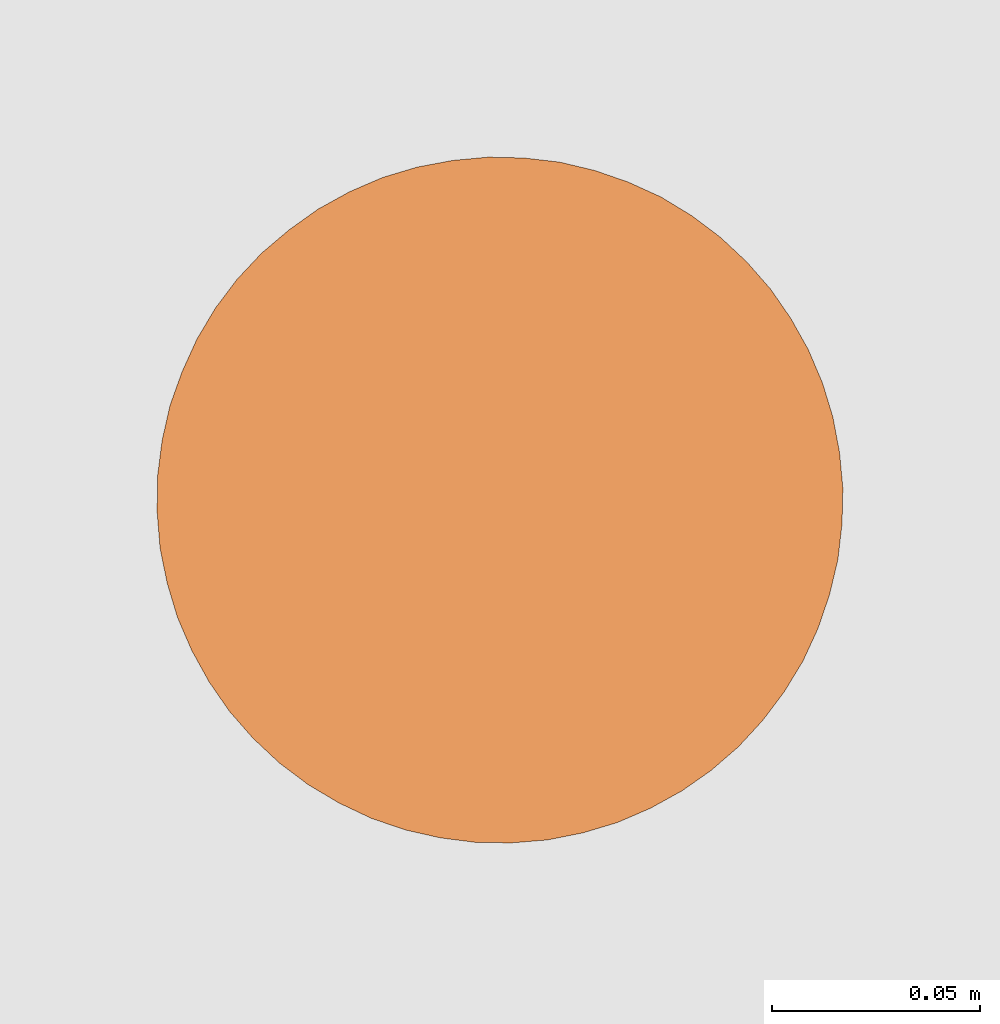
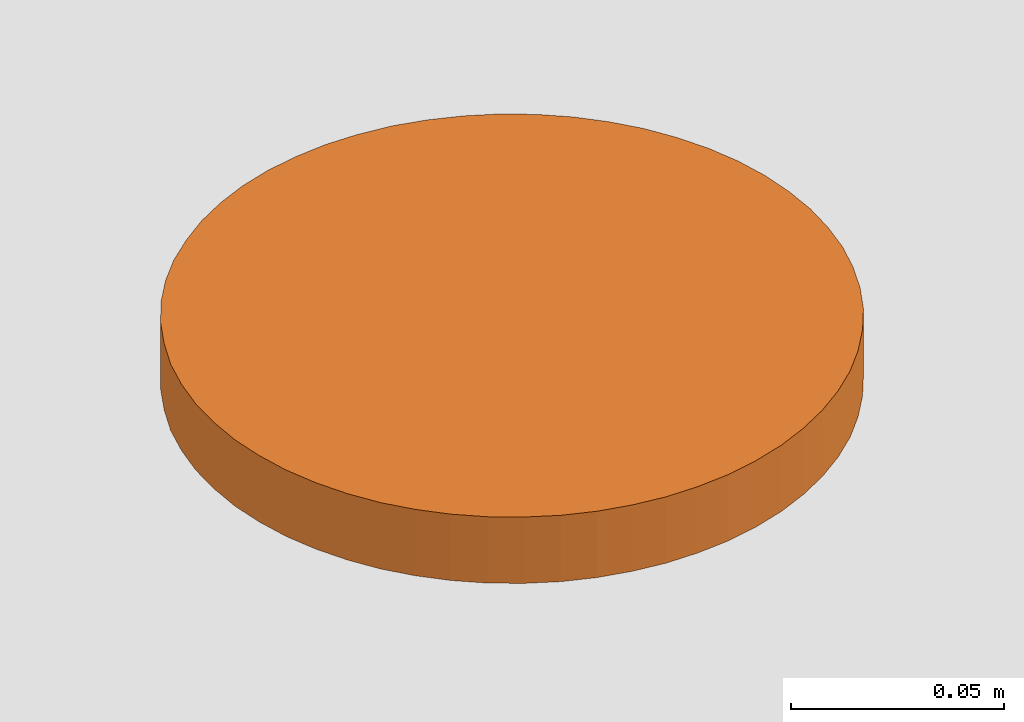
# One storey, part 86 of 126: 1 proxy.
"""IFC2X3 building model written with IfcOpenShell, lengths in millimetres."""

from ifc_helpers import new_model, si_unit, origin, origin_with_axes, place, context, project, spatial, faceted_brep, material, element, save


model = new_model("IFC2X3")

# Units and contexts
context_of_model_1 = context(None, 3, precision=0.1, world=origin())
context_of_model_2 = context(None, 3, precision=0.1, world=origin())
ifc_project = project(units=[si_unit("LENGTHUNIT", "METRE", prefix="MILLI"), si_unit("AREAUNIT", "SQUARE_METRE", prefix="CENTI"), si_unit("VOLUMEUNIT", "CUBIC_METRE", prefix="CENTI"), si_unit("MASSUNIT", "GRAM", prefix="KILO")], contexts=[context_of_model_1, context_of_model_2])

# Site, building, storey
site_placement = place(None, origin_with_axes())
site = spatial("IfcSite", under=ifc_project, at=site_placement, CompositionType="ELEMENT")
building_placement = place(site_placement, origin_with_axes())
building = spatial("IfcBuilding", under=site, at=building_placement, CompositionType="ELEMENT")
storey_placement = place(building_placement, origin_with_axes())
storey = spatial("IfcBuildingStorey", under=building, at=storey_placement, CompositionType="ELEMENT")

# Proxy
ifc_material = material(Name="STAHL")
proxy_placement = place(storey_placement, origin_with_axes())
element("IfcBuildingElementProxy", 1, at=proxy_placement, inside=storey, material=ifc_material, Name="profile", context=context_of_model_2, shape_type="Brep", body=[
    faceted_brep([(6813.8, 14727.6, 10998.9), (6822.3, 14729.2, 10998.9), (6822.3, 14729.2, 10979.9), (6813.8, 14727.6, 10979.9), (6805.5, 14725.1, 10998.9), (6805.5, 14725.1, 10979.9), (6797.6, 14721.7, 10998.9), (6797.6, 14721.7, 10979.9), (6916.0, 14641.8, 10998.9), (6915.0, 14633.2, 10998.9), (6915.0, 14633.2, 10979.9), (6916.0, 14641.8, 10979.9), (6790.0, 14717.5, 10998.9), (6790.0, 14717.5, 10979.9), (6916.2, 14650.4, 10998.9), (6916.2, 14650.4, 10979.9), (6783.0, 14712.5, 10998.9), (6783.0, 14712.5, 10979.9), (6915.4, 14659.0, 10998.9), (6915.4, 14659.0, 10979.9), (6776.4, 14706.9, 10998.9), (6776.4, 14706.9, 10979.9), (6913.8, 14667.5, 10998.9), (6913.8, 14667.5, 10979.9), (6770.5, 14700.6, 10998.9), (6770.5, 14700.6, 10979.9), (6911.3, 14675.7, 10998.9), (6911.3, 14675.7, 10979.9), (6765.3, 14693.7, 10998.9), (6765.3, 14693.7, 10979.9), (6907.9, 14683.7, 10998.9), (6907.9, 14683.7, 10979.9), (6760.9, 14686.3, 10998.9), (6760.9, 14686.3, 10979.9), (6903.7, 14691.2, 10998.9), (6903.7, 14691.2, 10979.9), (6757.3, 14678.4, 10998.9), (6757.3, 14678.4, 10979.9), (6898.8, 14698.3, 10998.9), (6898.8, 14698.3, 10979.9), (6754.4, 14670.3, 10998.9), (6754.4, 14670.3, 10979.9), (6893.1, 14704.8, 10998.9), (6893.1, 14704.8, 10979.9), (6752.5, 14661.9, 10998.9), (6752.5, 14661.9, 10979.9), (6886.8, 14710.7, 10998.9), (6886.8, 14710.7, 10979.9), (6879.9, 14715.9, 10998.9), (6879.9, 14715.9, 10979.9), (6872.5, 14720.4, 10998.9), (6872.5, 14720.4, 10979.9), (6864.6, 14724.0, 10998.9), (6864.6, 14724.0, 10979.9), (6856.5, 14726.8, 10998.9), (6856.5, 14726.8, 10979.9), (6848.1, 14728.8, 10998.9), (6848.1, 14728.8, 10979.9), (6839.5, 14729.8, 10998.9), (6839.5, 14729.8, 10979.9), (6830.9, 14730.0, 10998.9), (6830.9, 14730.0, 10979.9), (6864.5, 14647.5, 10998.9), (6864.5, 14647.5, 10979.9), (6864.0, 14642.2, 10979.9), (6864.0, 14642.2, 10998.9), (6864.0, 14652.9, 10998.9), (6864.0, 14652.9, 10979.9), (6862.6, 14658.0, 10998.9), (6862.6, 14658.0, 10979.9), (6860.4, 14662.9, 10998.9), (6860.4, 14662.9, 10979.9), (6857.3, 14667.3, 10998.9), (6857.3, 14667.3, 10979.9), (6853.5, 14671.1, 10998.9), (6853.5, 14671.1, 10979.9), (6849.1, 14674.2, 10998.9), (6849.1, 14674.2, 10979.9), (6844.3, 14676.4, 10998.9), (6844.3, 14676.4, 10979.9), (6839.1, 14677.8, 10998.9), (6839.1, 14677.8, 10979.9), (6833.7, 14678.3, 10998.9), (6833.7, 14678.3, 10979.9), (6828.4, 14677.8, 10998.9), (6828.4, 14677.8, 10979.9), (6823.2, 14676.4, 10998.9), (6823.2, 14676.4, 10979.9), (6818.4, 14674.2, 10998.9), (6818.4, 14674.2, 10979.9), (6814.0, 14671.1, 10998.9), (6814.0, 14671.1, 10979.9), (6810.2, 14667.3, 10998.9), (6810.2, 14667.3, 10979.9), (6807.1, 14662.9, 10998.9), (6807.1, 14662.9, 10979.9), (6804.8, 14658.0, 10998.9), (6804.8, 14658.0, 10979.9), (6803.5, 14652.9, 10998.9), (6803.5, 14652.9, 10979.9), (6878.5, 14594.8, 10998.9), (6878.6, 14596.9, 10998.9), (6878.6, 14596.9, 10979.9), (6878.5, 14594.8, 10979.9), (6878.2, 14599.1, 10998.9), (6878.2, 14599.1, 10979.9), (6877.3, 14601.0, 10998.9), (6877.3, 14601.0, 10979.9), (6875.9, 14602.7, 10998.9), (6875.9, 14602.7, 10979.9), (6874.2, 14604.1, 10998.9), (6874.2, 14604.1, 10979.9), (6872.2, 14604.9, 10998.9), (6872.2, 14604.9, 10979.9), (6870.1, 14605.3, 10998.9), (6870.1, 14605.3, 10979.9), (6867.9, 14605.2, 10998.9), (6867.9, 14605.2, 10979.9), (6865.8, 14604.5, 10998.9), (6865.8, 14604.5, 10979.9), (6864.0, 14603.4, 10998.9), (6864.0, 14603.4, 10979.9), (6862.5, 14601.8, 10998.9), (6862.5, 14601.8, 10979.9), (6861.4, 14600.0, 10998.9), (6861.4, 14600.0, 10979.9), (6860.7, 14597.9, 10998.9), (6860.7, 14597.9, 10979.9), (6806.8, 14697.2, 10998.9), (6806.9, 14699.3, 10998.9), (6806.9, 14699.3, 10979.9), (6806.8, 14697.2, 10979.9), (6806.5, 14701.5, 10998.9), (6806.5, 14701.5, 10979.9), (6805.6, 14703.4, 10998.9), (6805.6, 14703.4, 10979.9), (6804.2, 14705.1, 10998.9), (6804.2, 14705.1, 10979.9), (6802.5, 14706.5, 10998.9), (6802.5, 14706.5, 10979.9), (6800.5, 14707.3, 10998.9), (6800.5, 14707.3, 10979.9), (6798.4, 14707.7, 10998.9), (6798.4, 14707.7, 10979.9), (6796.2, 14707.6, 10998.9), (6796.2, 14707.6, 10979.9), (6794.1, 14706.9, 10998.9), (6794.1, 14706.9, 10979.9), (6792.3, 14705.8, 10998.9), (6792.3, 14705.8, 10979.9), (6790.8, 14704.2, 10998.9), (6790.8, 14704.2, 10979.9), (6789.7, 14702.4, 10998.9), (6789.7, 14702.4, 10979.9), (6789.0, 14700.3, 10998.9), (6789.0, 14700.3, 10979.9), (6893.8, 14681.8, 10998.9), (6893.9, 14684.0, 10998.9), (6893.9, 14684.0, 10979.9), (6893.8, 14681.8, 10979.9), (6893.5, 14686.1, 10998.9), (6893.5, 14686.1, 10979.9), (6892.6, 14688.1, 10998.9), (6892.6, 14688.1, 10979.9), (6891.3, 14689.8, 10998.9), (6891.3, 14689.8, 10979.9), (6889.5, 14691.1, 10998.9), (6889.5, 14691.1, 10979.9), (6887.6, 14692.0, 10998.9), (6887.6, 14692.0, 10979.9), (6885.4, 14692.4, 10998.9), (6885.4, 14692.4, 10979.9), (6883.3, 14692.2, 10998.9), (6883.3, 14692.2, 10979.9), (6881.2, 14691.6, 10998.9), (6881.2, 14691.6, 10979.9), (6879.3, 14690.4, 10998.9), (6879.3, 14690.4, 10979.9), (6877.8, 14688.9, 10998.9), (6877.8, 14688.9, 10979.9), (6876.7, 14687.0, 10998.9), (6876.7, 14687.0, 10979.9), (6876.1, 14684.9, 10998.9), (6876.1, 14684.9, 10979.9), (6791.4, 14610.1, 10998.9), (6791.5, 14612.3, 10998.9), (6791.5, 14612.3, 10979.9), (6791.4, 14610.1, 10979.9), (6791.1, 14614.4, 10998.9), (6791.1, 14614.4, 10979.9), (6790.2, 14616.4, 10998.9), (6790.2, 14616.4, 10979.9), (6788.9, 14618.1, 10998.9), (6788.9, 14618.1, 10979.9), (6787.2, 14619.4, 10998.9), (6787.2, 14619.4, 10979.9), (6785.2, 14620.3, 10998.9), (6785.2, 14620.3, 10979.9), (6783.0, 14620.7, 10998.9), (6783.0, 14620.7, 10979.9), (6780.9, 14620.5, 10998.9), (6780.9, 14620.5, 10979.9), (6778.8, 14619.9, 10998.9), (6778.8, 14619.9, 10979.9), (6776.9, 14618.7, 10998.9), (6776.9, 14618.7, 10979.9), (6775.4, 14617.2, 10998.9), (6775.4, 14617.2, 10979.9), (6774.3, 14615.3, 10998.9), (6774.3, 14615.3, 10979.9), (6773.7, 14613.2, 10998.9), (6773.7, 14613.2, 10979.9), (6773.6, 14611.1, 10998.9), (6773.6, 14611.1, 10979.9), (6774.0, 14608.9, 10998.9), (6774.0, 14608.9, 10979.9), (6774.9, 14607.0, 10998.9), (6774.9, 14607.0, 10979.9), (6776.2, 14605.3, 10998.9), (6776.2, 14605.3, 10979.9), (6777.9, 14603.9, 10998.9), (6777.9, 14603.9, 10979.9), (6779.9, 14603.1, 10998.9), (6779.9, 14603.1, 10979.9), (6782.1, 14602.7, 10998.9), (6782.1, 14602.7, 10979.9), (6784.2, 14602.8, 10998.9), (6784.2, 14602.8, 10979.9), (6786.3, 14603.5, 10998.9), (6786.3, 14603.5, 10979.9), (6788.1, 14604.6, 10998.9), (6788.1, 14604.6, 10979.9), (6789.7, 14606.2, 10998.9), (6789.7, 14606.2, 10979.9), (6790.8, 14608.0, 10998.9), (6790.8, 14608.0, 10979.9), (6876.0, 14682.8, 10998.9), (6876.0, 14682.8, 10979.9), (6876.4, 14680.6, 10998.9), (6876.4, 14680.6, 10979.9), (6877.3, 14678.7, 10998.9), (6877.3, 14678.7, 10979.9), (6878.6, 14677.0, 10998.9), (6878.6, 14677.0, 10979.9), (6880.3, 14675.6, 10998.9), (6880.3, 14675.6, 10979.9), (6882.3, 14674.8, 10998.9), (6882.3, 14674.8, 10979.9), (6884.5, 14674.4, 10998.9), (6884.5, 14674.4, 10979.9), (6886.6, 14674.5, 10998.9), (6886.6, 14674.5, 10979.9), (6888.7, 14675.2, 10998.9), (6888.7, 14675.2, 10979.9), (6890.5, 14676.3, 10998.9), (6890.5, 14676.3, 10979.9), (6892.1, 14677.9, 10998.9), (6892.1, 14677.9, 10979.9), (6893.2, 14679.7, 10998.9), (6893.2, 14679.7, 10979.9), (6788.9, 14698.1, 10998.9), (6788.9, 14698.1, 10979.9), (6789.3, 14696.0, 10998.9), (6789.3, 14696.0, 10979.9), (6790.2, 14694.0, 10998.9), (6790.2, 14694.0, 10979.9), (6791.6, 14692.3, 10998.9), (6791.6, 14692.3, 10979.9), (6793.3, 14691.0, 10998.9), (6793.3, 14691.0, 10979.9), (6795.3, 14690.1, 10998.9), (6795.3, 14690.1, 10979.9), (6797.4, 14689.7, 10998.9), (6797.4, 14689.7, 10979.9), (6799.6, 14689.9, 10998.9), (6799.6, 14689.9, 10979.9), (6801.6, 14690.5, 10998.9), (6801.6, 14690.5, 10979.9), (6803.5, 14691.7, 10998.9), (6803.5, 14691.7, 10979.9), (6805.0, 14693.2, 10998.9), (6805.0, 14693.2, 10979.9), (6806.1, 14695.1, 10998.9), (6806.1, 14695.1, 10979.9), (6860.6, 14595.7, 10998.9), (6860.6, 14595.7, 10979.9), (6861.0, 14593.6, 10998.9), (6861.0, 14593.6, 10979.9), (6861.9, 14591.6, 10998.9), (6861.9, 14591.6, 10979.9), (6863.3, 14589.9, 10998.9), (6863.3, 14589.9, 10979.9), (6865.0, 14588.6, 10998.9), (6865.0, 14588.6, 10979.9), (6867.0, 14587.7, 10998.9), (6867.0, 14587.7, 10979.9), (6869.1, 14587.3, 10998.9), (6869.1, 14587.3, 10979.9), (6871.3, 14587.5, 10998.9), (6871.3, 14587.5, 10979.9), (6873.3, 14588.1, 10998.9), (6873.3, 14588.1, 10979.9), (6875.2, 14589.3, 10998.9), (6875.2, 14589.3, 10979.9), (6876.7, 14590.8, 10998.9), (6876.7, 14590.8, 10979.9), (6877.8, 14592.7, 10998.9), (6877.8, 14592.7, 10979.9), (6836.6, 14565.1, 10998.9), (6845.2, 14565.8, 10998.9), (6853.7, 14567.5, 10998.9), (6862.0, 14570.0, 10998.9), (6869.9, 14573.4, 10998.9), (6877.5, 14577.6, 10998.9), (6884.5, 14582.5, 10998.9), (6891.1, 14588.2, 10998.9), (6896.9, 14594.5, 10998.9), (6902.1, 14601.4, 10998.9), (6906.6, 14608.8, 10998.9), (6862.6, 14637.0, 10998.9), (6860.4, 14632.2, 10998.9), (6857.3, 14627.8, 10998.9), (6853.5, 14624.0, 10998.9), (6849.1, 14620.9, 10998.9), (6844.3, 14618.6, 10998.9), (6839.1, 14617.2, 10998.9), (6833.7, 14616.8, 10998.9), (6828.4, 14617.2, 10998.9), (6823.2, 14618.6, 10998.9), (6818.4, 14620.9, 10998.9), (6814.0, 14624.0, 10998.9), (6810.2, 14627.8, 10998.9), (6807.1, 14632.2, 10998.9), (6804.8, 14637.0, 10998.9), (6803.5, 14642.2, 10998.9), (6803.0, 14647.5, 10998.9), (6910.2, 14616.6, 10998.9), (6913.0, 14624.8, 10998.9), (6751.4, 14653.3, 10998.9), (6751.3, 14644.6, 10998.9), (6752.0, 14636.0, 10998.9), (6753.7, 14627.6, 10998.9), (6756.2, 14619.3, 10998.9), (6759.6, 14611.4, 10998.9), (6763.8, 14603.8, 10998.9), (6768.7, 14596.7, 10998.9), (6774.4, 14590.2, 10998.9), (6780.7, 14584.3, 10998.9), (6787.6, 14579.1, 10998.9), (6795.0, 14574.7, 10998.9), (6802.8, 14571.0, 10998.9), (6811.0, 14568.2, 10998.9), (6819.4, 14566.3, 10998.9), (6828.0, 14565.2, 10998.9), (6836.6, 14565.1, 10979.9), (6828.0, 14565.2, 10979.9), (6819.4, 14566.3, 10979.9), (6811.0, 14568.2, 10979.9), (6802.8, 14571.0, 10979.9), (6795.0, 14574.7, 10979.9), (6787.6, 14579.1, 10979.9), (6780.7, 14584.3, 10979.9), (6774.4, 14590.2, 10979.9), (6768.7, 14596.7, 10979.9), (6763.8, 14603.8, 10979.9), (6759.6, 14611.4, 10979.9), (6756.2, 14619.3, 10979.9), (6753.7, 14627.6, 10979.9), (6752.0, 14636.0, 10979.9), (6751.3, 14644.6, 10979.9), (6751.4, 14653.3, 10979.9), (6913.0, 14624.8, 10979.9), (6910.2, 14616.6, 10979.9), (6906.6, 14608.8, 10979.9), (6902.1, 14601.4, 10979.9), (6833.7, 14616.8, 10979.9), (6839.1, 14617.2, 10979.9), (6844.3, 14618.6, 10979.9), (6849.1, 14620.9, 10979.9), (6853.5, 14624.0, 10979.9), (6857.3, 14627.8, 10979.9), (6860.4, 14632.2, 10979.9), (6862.6, 14637.0, 10979.9), (6803.0, 14647.5, 10979.9), (6803.5, 14642.2, 10979.9), (6804.8, 14637.0, 10979.9), (6807.1, 14632.2, 10979.9), (6810.2, 14627.8, 10979.9), (6814.0, 14624.0, 10979.9), (6818.4, 14620.9, 10979.9), (6823.2, 14618.6, 10979.9), (6828.4, 14617.2, 10979.9), (6896.9, 14594.5, 10979.9), (6891.1, 14588.2, 10979.9), (6884.5, 14582.5, 10979.9), (6877.5, 14577.6, 10979.9), (6869.9, 14573.4, 10979.9), (6862.0, 14570.0, 10979.9), (6853.7, 14567.5, 10979.9), (6845.2, 14565.8, 10979.9)], [[[0, 1, 2, 3]], [[4, 0, 3, 5]], [[6, 4, 5, 7]], [[8, 9, 10, 11]], [[12, 6, 7, 13]], [[14, 8, 11, 15]], [[16, 12, 13, 17]], [[18, 14, 15, 19]], [[20, 16, 17, 21]], [[22, 18, 19, 23]], [[24, 20, 21, 25]], [[26, 22, 23, 27]], [[28, 24, 25, 29]], [[30, 26, 27, 31]], [[32, 28, 29, 33]], [[34, 30, 31, 35]], [[36, 32, 33, 37]], [[38, 34, 35, 39]], [[40, 36, 37, 41]], [[42, 38, 39, 43]], [[44, 40, 41, 45]], [[46, 42, 43, 47]], [[48, 46, 47, 49]], [[50, 48, 49, 51]], [[52, 50, 51, 53]], [[54, 52, 53, 55]], [[56, 54, 55, 57]], [[58, 56, 57, 59]], [[60, 58, 59, 61]], [[1, 60, 61, 2]], [[62, 63, 64, 65]], [[66, 67, 63, 62]], [[68, 69, 67, 66]], [[70, 71, 69, 68]], [[72, 73, 71, 70]], [[74, 75, 73, 72]], [[76, 77, 75, 74]], [[78, 79, 77, 76]], [[80, 81, 79, 78]], [[82, 83, 81, 80]], [[84, 85, 83, 82]], [[86, 87, 85, 84]], [[88, 89, 87, 86]], [[90, 91, 89, 88]], [[92, 93, 91, 90]], [[94, 95, 93, 92]], [[96, 97, 95, 94]], [[98, 99, 97, 96]], [[100, 101, 102, 103]], [[101, 104, 105, 102]], [[104, 106, 107, 105]], [[106, 108, 109, 107]], [[108, 110, 111, 109]], [[110, 112, 113, 111]], [[112, 114, 115, 113]], [[114, 116, 117, 115]], [[116, 118, 119, 117]], [[118, 120, 121, 119]], [[120, 122, 123, 121]], [[122, 124, 125, 123]], [[124, 126, 127, 125]], [[128, 129, 130, 131]], [[129, 132, 133, 130]], [[132, 134, 135, 133]], [[134, 136, 137, 135]], [[136, 138, 139, 137]], [[138, 140, 141, 139]], [[140, 142, 143, 141]], [[142, 144, 145, 143]], [[144, 146, 147, 145]], [[146, 148, 149, 147]], [[148, 150, 151, 149]], [[150, 152, 153, 151]], [[152, 154, 155, 153]], [[156, 157, 158, 159]], [[157, 160, 161, 158]], [[160, 162, 163, 161]], [[162, 164, 165, 163]], [[164, 166, 167, 165]], [[166, 168, 169, 167]], [[168, 170, 171, 169]], [[170, 172, 173, 171]], [[172, 174, 175, 173]], [[174, 176, 177, 175]], [[176, 178, 179, 177]], [[178, 180, 181, 179]], [[180, 182, 183, 181]], [[184, 185, 186, 187]], [[185, 188, 189, 186]], [[188, 190, 191, 189]], [[190, 192, 193, 191]], [[192, 194, 195, 193]], [[194, 196, 197, 195]], [[196, 198, 199, 197]], [[198, 200, 201, 199]], [[200, 202, 203, 201]], [[202, 204, 205, 203]], [[204, 206, 207, 205]], [[206, 208, 209, 207]], [[210, 211, 209, 208]], [[210, 212, 213, 211]], [[212, 214, 215, 213]], [[214, 216, 217, 215]], [[216, 218, 219, 217]], [[218, 220, 221, 219]], [[220, 222, 223, 221]], [[222, 224, 225, 223]], [[224, 226, 227, 225]], [[226, 228, 229, 227]], [[228, 230, 231, 229]], [[230, 232, 233, 231]], [[232, 234, 235, 233]], [[234, 184, 187, 235]], [[236, 237, 183, 182]], [[238, 239, 237, 236]], [[240, 241, 239, 238]], [[242, 243, 241, 240]], [[244, 245, 243, 242]], [[246, 247, 245, 244]], [[248, 249, 247, 246]], [[250, 251, 249, 248]], [[252, 253, 251, 250]], [[254, 255, 253, 252]], [[256, 257, 255, 254]], [[258, 259, 257, 256]], [[156, 159, 259, 258]], [[260, 261, 155, 154]], [[260, 262, 263, 261]], [[262, 264, 265, 263]], [[264, 266, 267, 265]], [[266, 268, 269, 267]], [[268, 270, 271, 269]], [[270, 272, 273, 271]], [[272, 274, 275, 273]], [[274, 276, 277, 275]], [[276, 278, 279, 277]], [[278, 280, 281, 279]], [[280, 282, 283, 281]], [[282, 128, 131, 283]], [[126, 284, 285, 127]], [[284, 286, 287, 285]], [[286, 288, 289, 287]], [[288, 290, 291, 289]], [[290, 292, 293, 291]], [[292, 294, 295, 293]], [[294, 296, 297, 295]], [[296, 298, 299, 297]], [[298, 300, 301, 299]], [[300, 302, 303, 301]], [[302, 304, 305, 303]], [[304, 306, 307, 305]], [[306, 100, 103, 307]], [[308, 309, 310, 311, 312, 313, 314, 315, 316, 317, 318, 108, 106, 104, 101, 100, 306, 304, 302, 300, 298, 296, 294, 292, 290, 288, 286, 284, 126, 124, 122, 120, 118, 116, 114, 112, 110, 319, 320, 321, 322, 323, 324, 325, 326, 327, 328, 329, 330, 331, 332, 333, 334, 335, 200, 198, 196, 194, 192, 190, 188, 185, 184, 234, 232, 230, 228, 226, 224, 222, 220, 218, 216, 214, 212, 210, 208, 206, 204, 202, 200, 335, 98, 96, 94, 92, 90, 88, 86, 84, 82, 129, 128, 282, 280, 278, 276, 274, 272, 270, 268, 266, 264, 262, 260, 154, 152, 150, 148, 146, 144, 142, 140, 138, 136, 134, 132, 129, 82, 80, 78, 76, 74, 72, 70, 68, 66, 62, 250, 248, 246, 244, 242, 240, 238, 236, 182, 180, 178, 176, 174, 172, 170, 168, 166, 164, 162, 160, 157, 156, 258, 256, 254, 252, 250, 62, 65, 319, 110, 108, 318, 336, 337, 9, 8, 14, 18, 22, 26, 30, 34, 38, 42, 46, 48, 50, 52, 54, 56, 58, 60, 1, 0, 4, 6, 12, 16, 20, 24, 28, 32, 36, 40, 44, 338, 339, 340, 341, 342, 343, 344, 345, 346, 347, 348, 349, 350, 351, 352, 353]], [[354, 355, 356, 357, 358, 359, 360, 361, 362, 363, 364, 365, 366, 367, 368, 369, 370, 45, 41, 37, 33, 29, 25, 21, 17, 13, 7, 5, 3, 2, 61, 59, 57, 55, 53, 51, 49, 47, 43, 39, 35, 31, 27, 23, 19, 15, 11, 10, 371, 372, 373, 374, 105, 107, 109, 111, 113, 115, 117, 119, 121, 123, 125, 127, 285, 375, 376, 377, 378, 379, 380, 381, 382, 64, 63, 67, 69, 71, 73, 75, 77, 79, 181, 183, 237, 239, 241, 243, 245, 247, 249, 251, 253, 255, 257, 259, 159, 158, 161, 163, 165, 167, 169, 171, 173, 175, 177, 179, 181, 79, 81, 83, 85, 87, 89, 91, 93, 95, 97, 269, 271, 273, 275, 277, 279, 281, 283, 131, 130, 133, 135, 137, 139, 141, 143, 145, 147, 149, 151, 153, 155, 261, 263, 265, 267, 269, 97, 99, 383, 384, 385, 386, 387, 388, 389, 390, 235, 187, 186, 189, 191, 193, 195, 197, 199, 201, 203, 205, 207, 209, 211, 213, 215, 217, 219, 221, 223, 225, 227, 229, 231, 233, 235, 390, 391, 375, 285, 287, 289, 291, 293, 295, 297, 299, 301, 303, 305, 307, 103, 102, 105, 374, 392, 393, 394, 395, 396, 397, 398, 399]], [[98, 335, 383, 99]], [[335, 334, 384, 383]], [[334, 333, 385, 384]], [[333, 332, 386, 385]], [[332, 331, 387, 386]], [[331, 330, 388, 387]], [[330, 329, 389, 388]], [[329, 328, 390, 389]], [[328, 327, 391, 390]], [[327, 326, 375, 391]], [[326, 325, 376, 375]], [[325, 324, 377, 376]], [[324, 323, 378, 377]], [[323, 322, 379, 378]], [[322, 321, 380, 379]], [[321, 320, 381, 380]], [[320, 319, 382, 381]], [[319, 65, 64, 382]], [[312, 396, 395, 313]], [[313, 395, 394, 314]], [[44, 45, 370, 338]], [[314, 394, 393, 315]], [[338, 370, 369, 339]], [[315, 393, 392, 316]], [[339, 369, 368, 340]], [[316, 392, 374, 317]], [[340, 368, 367, 341]], [[317, 374, 373, 318]], [[341, 367, 366, 342]], [[318, 373, 372, 336]], [[342, 366, 365, 343]], [[336, 372, 371, 337]], [[343, 365, 364, 344]], [[337, 371, 10, 9]], [[344, 364, 363, 345]], [[345, 363, 362, 346]], [[346, 362, 361, 347]], [[347, 361, 360, 348]], [[348, 360, 359, 349]], [[349, 359, 358, 350]], [[350, 358, 357, 351]], [[351, 357, 356, 352]], [[352, 356, 355, 353]], [[353, 355, 354, 308]], [[308, 354, 399, 309]], [[309, 399, 398, 310]], [[310, 398, 397, 311]], [[311, 397, 396, 312]]]),
])

save(model, "model.ifc")
